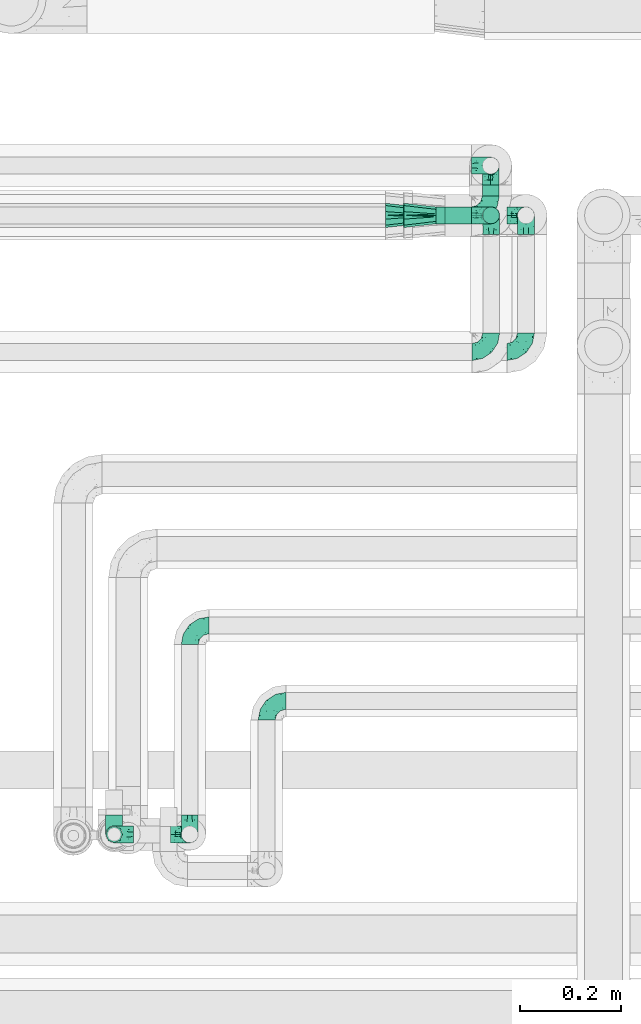
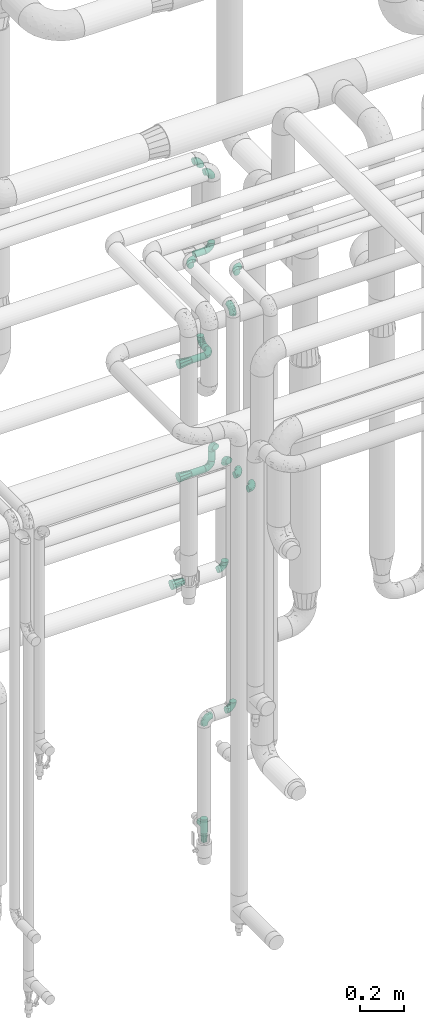
# One storey, part 776 of 827: 21 flow fittings, 5 flow segments.
"""IFC2X3 building model written with IfcOpenShell, lengths in millimetres."""

import ifcopenshell
import ifcopenshell.guid

model = None  # the IFC model being written
_history = None  # IfcOwnerHistory: only IFC2X3 demands one
_inside = {}  # id of a spatial element -> (the spatial element, [elements in it])
_under = {}  # id of a project, library or spatial element -> (it, [spatial elements below it])
_declared = {}  # id of a project -> (the project, [libraries it declares])
_typed = {}  # id of a type object -> (the type object, [elements of that type])
_made_of = {}  # id of a material, layer set ... -> (it, [elements and type objects made of it])


def new_model(schema):
    """Start an empty IFC model of exactly this schema.

    Asked for "IFC4X3", IfcOpenShell would pick the latest addendum, in which some entities
    have other attributes; the version numbers below select the first issue.
    IFC2X3 requires an IfcOwnerHistory on every rooted entity: one is made here for all.
    """
    global model, _history
    if schema == "IFC4X3":
        model = ifcopenshell.file(schema_version=(4, 3, 0, 0))
    else:
        model = ifcopenshell.file(schema=schema)
    _inside.clear()
    _under.clear()
    _declared.clear()
    _typed.clear()
    _made_of.clear()
    _history = None
    if model.schema == "IFC2X3":
        org = make("IfcOrganization", Name="unknown")
        user = make(
            "IfcPersonAndOrganization",
            ThePerson=make("IfcPerson", FamilyName="unknown"),
            TheOrganization=org,
        )
        app = make(
            "IfcApplication",
            ApplicationDeveloper=org,
            Version="unknown",
            ApplicationFullName="unknown",
            ApplicationIdentifier="unknown",
        )
        _history = make(
            "IfcOwnerHistory",
            OwningUser=user,
            OwningApplication=app,
            ChangeAction="ADDED",
            CreationDate=0,
        )
    return model


def make(cls, **values):
    """One entity of the class cls with the attributes given. An attribute that is None is left unset."""
    return model.create_entity(
        cls, **{name: value for name, value in values.items() if value is not None}
    )


def entity(cls, *values):
    """Any entity or typed value of the class cls, its attributes in the order of the schema. None: left unset."""
    e = model.create_entity(cls)
    for i, value in enumerate(values):
        if value is not None:
            e[i] = value
    return e


def rooted(cls, **values):
    """An entity with a GlobalId (a new one), such as an element, a storey or a relation."""
    return make(cls, GlobalId=ifcopenshell.guid.new(), OwnerHistory=_history, **values)


def si_unit(unit_type, name, prefix=None):
    """IfcSIUnit, for example si_unit("LENGTHUNIT", "METRE", prefix="MILLI")."""
    return make("IfcSIUnit", UnitType=unit_type, Prefix=prefix, Name=name)


def converted_unit(unit_type, name, factor, base, dimensions=None, offset=None):
    """IfcConversionBasedUnit, such as the inch: factor (a typed value) times the base unit."""
    return make(
        "IfcConversionBasedUnit"
        if offset is None
        else "IfcConversionBasedUnitWithOffset",
        ConversionOffset=offset,
        Dimensions=None
        if dimensions is None
        else entity("IfcDimensionalExponents", *dimensions),
        UnitType=unit_type,
        Name=name,
        ConversionFactor=make(
            "IfcMeasureWithUnit", ValueComponent=factor, UnitComponent=base
        ),
    )


def derived_unit(unit_type, elements):
    """IfcDerivedUnit: a product of units, each with its exponent."""
    return make(
        "IfcDerivedUnit",
        Elements=[
            make("IfcDerivedUnitElement", Unit=unit, Exponent=power)
            for unit, power in elements
        ],
        UnitType=unit_type,
    )


def assignment(units):
    """IfcUnitAssignment: the units of a project."""
    return None if units is None else make("IfcUnitAssignment", Units=units)


def point(xyz):
    """IfcCartesianPoint."""
    return None if xyz is None else make("IfcCartesianPoint", Coordinates=xyz)


def direction(xyz):
    """IfcDirection."""
    return None if xyz is None else make("IfcDirection", DirectionRatios=xyz)


def frame(location, z_axis=None, x_axis=None):
    """IfcAxis2Placement3D, a coordinate frame: its origin and axes. An axis left out is left unset."""
    return make(
        "IfcAxis2Placement3D",
        Location=point(location),
        Axis=direction(z_axis),
        RefDirection=direction(x_axis),
    )


def frame_2d(location, x_axis=None):
    """IfcAxis2Placement2D, a coordinate frame in the plane: its origin and x axis."""
    return make(
        "IfcAxis2Placement2D", Location=point(location), RefDirection=direction(x_axis)
    )


def origin():
    """The frame at (0, 0, 0) with its axes left unset."""
    return frame((0.0, 0.0, 0.0))


def origin_2d_with_axis():
    """The frame at (0, 0) in the plane with the x axis (1, 0) written out."""
    return frame_2d((0.0, 0.0), x_axis=(1.0, 0.0))


def place(relative_to, where):
    """IfcLocalPlacement: puts the frame where relative to a parent placement (None: the world)."""
    return make(
        "IfcLocalPlacement", PlacementRelTo=relative_to, RelativePlacement=where
    )


def context(
    kind, dimensions, precision=None, world=None, true_north=None, identifier=None
):
    """IfcGeometricRepresentationContext, for example the 3D "Model" context."""
    return make(
        "IfcGeometricRepresentationContext",
        ContextIdentifier=identifier,
        ContextType=kind,
        CoordinateSpaceDimension=dimensions,
        Precision=precision,
        WorldCoordinateSystem=world,
        TrueNorth=true_north,
    )


def subcontext(parent, identifier, kind, view, scale=None):
    """IfcGeometricRepresentationSubContext, for example "Body" below "Model"."""
    return make(
        "IfcGeometricRepresentationSubContext",
        ContextIdentifier=identifier,
        ContextType=kind,
        ParentContext=parent,
        TargetScale=scale,
        TargetView=view,
    )


def project(units=None, contexts=None):
    """IfcProject with its units and contexts."""
    return rooted(
        "IfcProject",
        Name="project",
        RepresentationContexts=contexts,
        UnitsInContext=assignment(units),
    )


def spatial(cls, under=None, at=None, **own):
    """A site, building, storey or space (cls), placed at a placement, below another one or the project."""
    s = rooted(cls, ObjectPlacement=at, **own)
    if under is not None:
        _under.setdefault(under.id(), (under, []))[1].append(s)
    return s


def profile(cls, at=None, kind="AREA", **sizes):
    """A parametric profile (cls). Its sizes go by their IFC names, for example OverallWidth=200.0."""
    return make(cls, ProfileType=kind, Position=at, **sizes)


def circle(**sizes):
    """IfcCircleProfileDef."""
    return profile("IfcCircleProfileDef", **sizes)


def extrude(swept, where, along, depth):
    """IfcExtrudedAreaSolid: the profile swept, set in the frame where, extruded along a direction by depth."""
    return make(
        "IfcExtrudedAreaSolid",
        SweptArea=swept,
        Position=where,
        ExtrudedDirection=direction(along),
        Depth=depth,
    )


def faces_of(points, faces, orient=None, outer=None):
    """IfcFace entities. A face is a list of loops; a loop is a list of indices into points, from 0.

    orient and outer hold one flag for each loop. By default every Orientation is true, the
    first loop of a face is its IfcFaceOuterBound and the others are IfcFaceBound.
    """
    made = []
    for i, loops in enumerate(faces):
        bounds = []
        for j, loop in enumerate(loops):
            is_outer = j == 0 if outer is None else outer[i][j]
            bounds.append(
                make(
                    "IfcFaceOuterBound" if is_outer else "IfcFaceBound",
                    Bound=make("IfcPolyLoop", Polygon=[points[k] for k in loop]),
                    Orientation=True if orient is None else orient[i][j],
                )
            )
        made.append(make("IfcFace", Bounds=bounds))
    return made


def faceted_brep(points, faces, orient=None, outer=None, voids=None):
    """IfcFacetedBrep: a solid bounded by flat faces; with voids (closed shells), ...WithVoids."""
    shared = [point(p) for p in points]
    hull = make("IfcClosedShell", CfsFaces=faces_of(shared, faces, orient, outer))
    if voids is None:
        return make("IfcFacetedBrep", Outer=hull)
    return make(
        "IfcFacetedBrepWithVoids",
        Outer=hull,
        Voids=[
            make(cls, CfsFaces=faces_of(shared, fs, o, b)) for cls, fs, o, b in voids
        ],
    )


def shape(context_of_items, identifier, shape_type, items):
    """IfcShapeRepresentation: the items that make up one representation, for example the "Body"."""
    return make(
        "IfcShapeRepresentation",
        ContextOfItems=context_of_items,
        RepresentationIdentifier=identifier,
        RepresentationType=shape_type,
        Items=items,
    )


def source(mapping_origin, context_of_items, identifier, shape_type, items):
    """IfcRepresentationMap: a shape defined once, which mapped items show again and again."""
    return make(
        "IfcRepresentationMap",
        MappingOrigin=mapping_origin,
        MappedRepresentation=shape(context_of_items, identifier, shape_type, items),
    )


def transform(
    local_origin,
    x_axis=None,
    y_axis=None,
    z_axis=None,
    scale=None,
    scale2=None,
    scale3=None,
    uniform=True,
):
    """IfcCartesianTransformationOperator3D, or its non-uniform kind. x_axis, y_axis, z_axis: its Axis1, 2, 3."""
    if uniform:
        return make(
            "IfcCartesianTransformationOperator3D",
            Axis1=direction(x_axis),
            Axis2=direction(y_axis),
            LocalOrigin=point(local_origin),
            Scale=scale,
            Axis3=direction(z_axis),
        )
    return make(
        "IfcCartesianTransformationOperator3DnonUniform",
        Axis1=direction(x_axis),
        Axis2=direction(y_axis),
        LocalOrigin=point(local_origin),
        Scale=scale,
        Axis3=direction(z_axis),
        Scale2=scale2,
        Scale3=scale3,
    )


def mapped(mapping_source, mapping_target):
    """IfcMappedItem: shows the shape of a source again, moved by a transform."""
    return make(
        "IfcMappedItem", MappingSource=mapping_source, MappingTarget=mapping_target
    )


def material(Name=None, Category=None):
    """IfcMaterial."""
    return make("IfcMaterial", Name=Name, Category=Category)


def made_of(thing, what):
    """Note that an element or type object is made of a material, layer set ...; save() writes the relation."""
    if what is not None:
        _made_of.setdefault(what.id(), (what, []))[1].append(thing)
    return thing


def type_object(cls, material=None, **own):
    """A type object (cls), such as IfcWallType, which elements share."""
    return made_of(rooted(cls, **own), material)


def type_shapes(of_type, sources):
    """Give a type object the sources (RepresentationMaps) that its elements show as mapped items."""
    of_type.RepresentationMaps = sources


def element(
    cls,
    number,
    at=None,
    inside=None,
    cuts=None,
    type_object=None,
    material=None,
    context=None,
    identifier="Body",
    shape_type=None,
    held_by="IfcProductDefinitionShape",
    body=None,
    shapes=None,
    **own,
):
    """One element of the class cls, such as IfcWall. Its Tag is "e" and its number.

    at: its placement. inside: the storey or other place that contains it. cuts: it is an
    opening in that element (IfcRelVoidsElement). A single representation is given by context,
    identifier, shape_type and body (its items); several are given by shapes. held_by: the class
    of the entity that holds the representations. save() writes the other relations.
    """
    e = rooted(cls, Tag="e%d" % number, ObjectPlacement=at, **own)
    if body is not None:
        shapes = [shape(context, identifier, shape_type, body)]
    if shapes is not None:
        e.Representation = make(held_by, Representations=shapes)
    if inside is not None:
        _inside.setdefault(inside.id(), (inside, []))[1].append(e)
    if cuts is not None:
        rooted(
            "IfcRelVoidsElement", RelatingBuildingElement=cuts, RelatedOpeningElement=e
        )
    if type_object is not None:
        _typed.setdefault(type_object.id(), (type_object, []))[1].append(e)
    return made_of(e, material)


def aggregate(whole, parts):
    """IfcRelAggregates: a whole, such as a stair, and the parts it consists of."""
    return rooted("IfcRelAggregates", RelatingObject=whole, RelatedObjects=parts)


def save(model, path):
    """Write the relations noted so far, then the file.

    IfcRelAggregates (storeys below a building ...), IfcRelContainedInSpatialStructure (elements
    in a storey), IfcRelDefinesByType, IfcRelAssociatesMaterial and IfcRelDeclares: one each for
    every whole, place, type object, material and project.
    """
    for whole, parts in _under.values():
        aggregate(whole, parts)
    for where, things in _inside.values():
        rooted(
            "IfcRelContainedInSpatialStructure",
            RelatedElements=things,
            RelatingStructure=where,
        )
    for kind, things in _typed.values():
        rooted("IfcRelDefinesByType", RelatedObjects=things, RelatingType=kind)
    for what, things in _made_of.values():
        rooted("IfcRelAssociatesMaterial", RelatedObjects=things, RelatingMaterial=what)
    for by, libraries in _declared.values():
        rooted("IfcRelDeclares", RelatingContext=by, RelatedDefinitions=libraries)
    model.write(path)


model = new_model("IFC2X3")

# Units and contexts
model_context = context("Model", 3, precision=0.01, world=origin(), true_north=direction((6.12303176911189e-17, 1.0)))
body_context = subcontext(model_context, "Body", "Model", "MODEL_VIEW")
ifc_project = project(units=[si_unit("LENGTHUNIT", "METRE", prefix="MILLI"), si_unit("AREAUNIT", "SQUARE_METRE"), si_unit("VOLUMEUNIT", "CUBIC_METRE"), converted_unit("PLANEANGLEUNIT", "DEGREE", entity("IfcRatioMeasure", 0.0174532925199433), si_unit("PLANEANGLEUNIT", "RADIAN"), dimensions=[0, 0, 0, 0, 0, 0, 0]), si_unit("MASSUNIT", "GRAM", prefix="KILO"), derived_unit("MASSDENSITYUNIT", [(si_unit("MASSUNIT", "GRAM", prefix="KILO"), 1), (si_unit("LENGTHUNIT", "METRE"), -3)]), derived_unit("MOMENTOFINERTIAUNIT", [(si_unit("LENGTHUNIT", "METRE"), 4)]), si_unit("TIMEUNIT", "SECOND"), si_unit("FREQUENCYUNIT", "HERTZ"), si_unit("THERMODYNAMICTEMPERATUREUNIT", "DEGREE_CELSIUS"), derived_unit("THERMALTRANSMITTANCEUNIT", [(si_unit("MASSUNIT", "GRAM", prefix="KILO"), 1), (si_unit("THERMODYNAMICTEMPERATUREUNIT", "KELVIN"), -1), (si_unit("TIMEUNIT", "SECOND"), -3)]), derived_unit("VOLUMETRICFLOWRATEUNIT", [(si_unit("LENGTHUNIT", "METRE"), 3), (si_unit("TIMEUNIT", "SECOND"), -1)]), derived_unit("MASSFLOWRATEUNIT", [(si_unit("MASSUNIT", "GRAM", prefix="KILO"), 1), (si_unit("TIMEUNIT", "SECOND"), -1)]), derived_unit("ROTATIONALFREQUENCYUNIT", [(si_unit("TIMEUNIT", "SECOND"), -1)]), si_unit("ELECTRICCURRENTUNIT", "AMPERE"), si_unit("ELECTRICVOLTAGEUNIT", "VOLT"), si_unit("POWERUNIT", "WATT"), si_unit("FORCEUNIT", "NEWTON", prefix="KILO"), si_unit("ILLUMINANCEUNIT", "LUX"), si_unit("LUMINOUSFLUXUNIT", "LUMEN"), si_unit("LUMINOUSINTENSITYUNIT", "CANDELA"), derived_unit("USERDEFINED", [(si_unit("MASSUNIT", "GRAM", prefix="KILO"), -1), (si_unit("LENGTHUNIT", "METRE"), -2), (si_unit("TIMEUNIT", "SECOND"), 3), (si_unit("LUMINOUSFLUXUNIT", "LUMEN"), 1)]), derived_unit("LINEARVELOCITYUNIT", [(si_unit("LENGTHUNIT", "METRE"), 1), (si_unit("TIMEUNIT", "SECOND"), -1)]), si_unit("PRESSUREUNIT", "PASCAL"), derived_unit("USERDEFINED", [(si_unit("LENGTHUNIT", "METRE"), -2), (si_unit("MASSUNIT", "GRAM", prefix="KILO"), 1), (si_unit("TIMEUNIT", "SECOND"), -2)]), derived_unit("LINEARFORCEUNIT", [(si_unit("MASSUNIT", "GRAM", prefix="KILO"), 1), (si_unit("LENGTHUNIT", "METRE"), 1), (si_unit("TIMEUNIT", "SECOND"), -2), (si_unit("LENGTHUNIT", "METRE"), -1)]), derived_unit("PLANARFORCEUNIT", [(si_unit("MASSUNIT", "GRAM", prefix="KILO"), 1), (si_unit("LENGTHUNIT", "METRE"), 1), (si_unit("TIMEUNIT", "SECOND"), -2), (si_unit("LENGTHUNIT", "METRE"), -2)])], contexts=[model_context])

# Site, building, storey
site_placement = place(None, origin())
site = spatial("IfcSite", under=ifc_project, at=site_placement, CompositionType="ELEMENT")
building_placement = place(site_placement, origin())
building = spatial("IfcBuilding", under=site, at=building_placement, CompositionType="ELEMENT")
storey_placement = place(building_placement, frame((0.0, 0.0, 28200.0)))
storey = spatial("IfcBuildingStorey", under=building, at=storey_placement, Name="08", CompositionType="ELEMENT", Elevation=28200.0)

# Flow segments
pipe_segment_type = type_object("IfcPipeSegmentType", PredefinedType="NOTDEFINED")
flow_segment_1_placement = place(storey_placement, frame((56544.88, 17538.0, 1974.15)))
element("IfcFlowSegment", 1, at=flow_segment_1_placement, inside=storey, type_object=pipe_segment_type, context=body_context, shape_type="SweptSolid", body=[
    extrude(circle(Radius=16.75, at=origin_2d_with_axis()), frame((18.35, 0.0, 18.35), z_axis=(0.0, 1.0, 0.0), x_axis=(-1.0, 0.0, 0.0)), (0.0, 0.0, 1.0), 22.8207544577575),
])
flow_segment_2_placement = place(storey_placement, frame((56454.69, 17481.65, 1974.15)))
element("IfcFlowSegment", 2, at=flow_segment_2_placement, inside=storey, type_object=pipe_segment_type, context=body_context, shape_type="SweptSolid", body=[
    extrude(circle(Radius=16.75, at=origin_2d_with_axis()), frame((0.0, 18.35, 18.35), z_axis=(1.0, 0.0, 0.0), x_axis=(0.0, 1.0, 0.0)), (0.0, 0.0, 1.0), 70.5388803777957),
])
flow_segment_3_placement = place(storey_placement, frame((56472.19, 17481.65, 2549.15)))
element("IfcFlowSegment", 3, at=flow_segment_3_placement, inside=storey, type_object=pipe_segment_type, context=body_context, shape_type="SweptSolid", body=[
    extrude(circle(Radius=16.75, at=origin_2d_with_axis()), frame((0.0, 18.35, 18.35), z_axis=(1.0, 0.0, 0.0), x_axis=(0.0, 1.0, 0.0)), (0.0, 0.0, 1.0), 53.0388803778343),
])
flow_segment_4_placement = place(storey_placement, frame((56454.23, 17481.65, 1351.65)))
element("IfcFlowSegment", 4, at=flow_segment_4_placement, inside=storey, type_object=pipe_segment_type, context=body_context, shape_type="SweptSolid", body=[
    extrude(circle(Radius=16.75, at=origin_2d_with_axis()), frame((0.0, 18.35, 18.35), z_axis=(1.0, 0.0, 0.0), x_axis=(0.0, 1.0, 0.0)), (0.0, 0.0, 1.0), 72.0000000000269),
])
flow_segment_5_placement = place(storey_placement, frame((56545.88, 17481.65, 1408.0)))
element("IfcFlowSegment", 5, at=flow_segment_5_placement, inside=storey, type_object=pipe_segment_type, context=body_context, shape_type="SweptSolid", body=[
    extrude(circle(Radius=16.75, at=origin_2d_with_axis()), frame((18.35, 18.35, 0.0)), (0.0, 0.0, 1.0), 54.0000000000267),
])

# Flow fittings
ifc_material = material()
pipe_fitting_type_1 = type_object("IfcPipeFittingType", Name="ADSK_1", PredefinedType="NOTDEFINED", material=ifc_material)
shared_shape_1 = source(origin(), body_context, "Body", "Brep", [
    faceted_brep([(-38.0, 0.0, -16.85), (-38.0, -4.36, -16.28), (-38.0, -8.43, -14.59), (-38.0, -11.91, -11.91), (-38.0, -14.59, -8.43), (-38.0, -16.28, -4.36), (-38.0, -16.85, 0.0), (-38.0, -16.28, 4.36), (-38.0, -14.59, 8.42), (-38.0, -11.91, 11.91), (-38.0, -8.43, 14.59), (-38.0, -4.36, 16.28), (-38.0, 0.0, 16.85), (-38.0, 4.36, 16.28), (-38.0, 8.42, 14.59), (-38.0, 11.91, 11.91), (-38.0, 14.59, 8.42), (-38.0, 16.28, 4.36), (-38.0, 16.85, 0.0), (-38.0, 16.28, -4.36), (-38.0, 14.59, -8.43), (-38.0, 11.91, -11.91), (-38.0, 8.42, -14.59), (-38.0, 4.36, -16.28), (-4.36, 38.0, -16.28), (-8.42, 38.0, -14.59), (-11.91, 38.0, -11.91), (-14.59, 38.0, -8.43), (-16.28, 38.0, -4.36), (-16.85, 38.0, 0.0), (-16.28, 38.0, 4.36), (-14.59, 38.0, 8.42), (-11.91, 38.0, 11.91), (-8.42, 38.0, 14.59), (-4.36, 38.0, 16.28), (0.0, 38.0, 16.85), (4.36, 38.0, 16.28), (8.43, 38.0, 14.59), (11.91, 38.0, 11.91), (14.59, 38.0, 8.42), (16.28, 38.0, 4.36), (16.85, 38.0, 0.0), (16.28, 38.0, -4.36), (14.59, 38.0, -8.43), (11.91, 38.0, -11.91), (8.43, 38.0, -14.59), (4.36, 38.0, -16.28), (0.0, 38.0, -16.85), (-27.9, -12.9, 9.54), (-27.5, -14.76, 0.0), (-16.53, -9.86, 8.66), (-24.93, -9.38, 12.63), (-29.29, -2.05, 16.58), (-26.82, 2.86, 16.81), (-25.18, -14.43, 5.37), (-4.54, 4.54, 14.04), (-15.36, -3.29, 14.19), (-7.56, -2.74, 10.9), (-28.06, -6.15, 15.21), (9.38, 24.93, 12.63), (-4.71, -4.42, 5.51), (-14.62, -10.99, 4.34), (-8.11, -6.73, 0.0), (-19.46, 0.42, 16.39), (-29.52, 14.25, 10.97), (-26.45, 18.14, 7.62), (-32.84, 15.94, 6.96), (-23.39, 16.22, 12.05), (-11.89, 8.53, 16.79), (-5.59, 13.42, 16.64), (-6.64, 18.62, 16.81), (-32.37, 10.35, 13.72), (-6.4, 32.67, 15.76), (-2.55, 28.48, 16.8), (6.81, 15.56, 11.71), (3.29, 15.36, 14.19), (-29.89, 18.0, 3.79), (-29.34, 6.81, 15.88), (-10.26, 4.27, 15.87), (-2.97, 11.0, 15.66), (2.45, 6.84, 10.65), (-1.8, -0.14, 8.44), (5.0, 5.5, 5.57), (-17.68, 27.4, 7.52), (14.43, 25.18, 5.37), (12.9, 27.9, 9.54), (9.86, 16.53, 8.66), (6.15, 28.06, 15.21), (-17.01, -12.67, 0.0), (2.05, 29.29, 16.58), (14.76, 27.5, 0.0), (10.99, 14.62, 4.34), (12.67, 17.01, 0.0), (-15.84, -6.82, 11.83), (-7.71, 25.61, 16.01), (-22.69, 22.69, 4.1), (-19.68, 27.42, 0.0), (-27.42, 19.68, 0.0), (-18.11, 29.67, 3.72), (-10.87, 29.33, 13.9), (-20.83, 21.64, 8.95), (-18.54, 20.86, 11.76), (-14.08, 30.19, 10.92), (-13.69, 20.27, 14.88), (-20.85, 7.92, 16.51), (-19.04, 4.79, 16.85), (-19.82, 12.26, 15.55), (-19.27, 16.43, 13.96), (-10.72, 19.56, 16.07), (-0.42, 19.46, 16.39), (-25.32, 12.08, 14.15), (-9.04, -6.0, 8.28), (-13.94, 13.94, 16.38), (0.78, -0.78, 0.0), (6.73, 8.11, 0.0), (-9.04, -6.0, -8.28), (-15.9, -7.04, -11.65), (-7.56, -2.74, -10.9), (6.15, 28.06, -15.21), (3.29, 15.36, -14.19), (-0.42, 19.46, -16.39), (-30.19, 14.08, -10.92), (-29.33, 10.87, -13.9), (-25.61, 7.71, -16.01), (-32.67, 6.4, -15.76), (-29.67, 18.11, -3.72), (-18.14, 26.45, -7.62), (-22.69, 22.69, -4.1), (-18.0, 29.89, -3.79), (-25.18, -14.43, -5.37), (-14.62, -10.99, -4.34), (-20.27, 13.69, -14.88), (-15.36, -3.29, -14.19), (-14.25, 29.52, -10.97), (-15.94, 32.84, -6.96), (-24.93, -9.38, -12.63), (-27.9, -12.9, -9.54), (6.81, 15.56, -11.71), (9.38, 24.93, -12.63), (-7.92, 20.85, -16.51), (-4.79, 19.04, -16.85), (-8.53, 11.89, -16.79), (-29.29, -2.05, -16.58), (-13.42, 5.59, -16.64), (-4.27, 10.26, -15.87), (-11.0, 2.97, -15.66), (-16.53, -9.86, -8.66), (-28.48, 2.55, -16.8), (-18.62, 6.64, -16.81), (10.99, 14.62, -4.34), (14.43, 25.18, -5.37), (-12.26, 19.82, -15.55), (-16.43, 19.27, -13.96), (12.9, 27.9, -9.54), (-10.35, 32.37, -13.72), (-6.81, 29.34, -15.88), (2.05, 29.29, -16.58), (-2.86, 26.82, -16.81), (-27.4, 17.68, -7.52), (5.0, 5.5, -5.57), (-16.22, 23.39, -12.05), (-28.06, -6.15, -15.21), (9.86, 16.53, -8.66), (-20.86, 18.54, -11.76), (-21.64, 20.83, -8.95), (-19.56, 10.72, -16.07), (-19.46, 0.42, -16.39), (-12.08, 25.32, -14.15), (-4.54, 4.54, -14.04), (-13.94, 13.94, -16.38), (2.45, 6.84, -10.65), (-4.71, -4.42, -5.51), (-1.8, -0.14, -8.44)], [[[0, 1, 2, 3, 4, 5, 6, 7, 8, 9, 10, 11, 12, 13, 14, 15, 16, 17, 18, 19, 20, 21, 22, 23]], [[24, 25, 26, 27, 28, 29, 30, 31, 32, 33, 34, 35, 36, 37, 38, 39, 40, 41, 42, 43, 44, 45, 46, 47]], [[8, 48, 9]], [[7, 6, 49]], [[48, 50, 51]], [[12, 52, 53]], [[8, 54, 48]], [[7, 54, 8]], [[55, 56, 57]], [[51, 10, 9]], [[51, 58, 10]], [[59, 38, 37]], [[60, 61, 62]], [[58, 56, 63]], [[64, 65, 66]], [[67, 65, 64]], [[68, 69, 70]], [[14, 71, 15]], [[11, 52, 12]], [[34, 72, 73]], [[12, 53, 13]], [[15, 64, 16]], [[74, 59, 75]], [[18, 17, 76]], [[66, 17, 16]], [[77, 13, 53]], [[13, 77, 14]], [[69, 78, 79]], [[80, 81, 82]], [[31, 30, 83]], [[84, 85, 86]], [[59, 87, 75]], [[61, 54, 88]], [[35, 89, 36]], [[84, 40, 39]], [[35, 34, 73]], [[90, 40, 84]], [[39, 38, 85]], [[10, 58, 11]], [[85, 84, 39]], [[91, 84, 86]], [[84, 92, 90]], [[87, 37, 36]], [[93, 56, 51]], [[94, 70, 73]], [[95, 96, 97]], [[84, 91, 92]], [[96, 98, 29]], [[33, 32, 99]], [[76, 95, 97]], [[100, 101, 83]], [[102, 99, 32]], [[65, 95, 76]], [[103, 94, 99]], [[95, 98, 96]], [[72, 99, 94]], [[72, 34, 33]], [[101, 99, 102]], [[7, 49, 54]], [[87, 59, 37]], [[104, 105, 68]], [[106, 103, 107]], [[106, 77, 104]], [[32, 31, 102]], [[94, 103, 108]], [[94, 108, 70]], [[89, 73, 109]], [[71, 64, 15]], [[110, 107, 67]], [[50, 48, 54]], [[51, 9, 48]], [[56, 58, 51]], [[88, 54, 49]], [[52, 58, 63]], [[50, 111, 93]], [[56, 55, 78]], [[38, 59, 85]], [[86, 85, 59]], [[89, 87, 36]], [[41, 40, 90]], [[109, 79, 75]], [[109, 75, 87]], [[75, 55, 80]], [[104, 77, 53]], [[71, 77, 110]], [[31, 83, 102]], [[101, 102, 83]], [[99, 101, 103]], [[106, 107, 110]], [[68, 70, 112]], [[109, 73, 70]], [[68, 112, 104]], [[68, 63, 78]], [[57, 93, 111]], [[80, 55, 57]], [[61, 50, 54]], [[80, 82, 86]], [[81, 57, 111]], [[74, 86, 59]], [[60, 113, 82]], [[82, 114, 91]], [[100, 95, 65]], [[98, 95, 83]], [[73, 89, 35]], [[87, 89, 109]], [[58, 52, 11]], [[53, 52, 63]], [[104, 53, 105]], [[106, 104, 112]], [[18, 76, 97]], [[76, 17, 66]], [[103, 106, 112]], [[77, 106, 110]], [[103, 101, 107]], [[67, 107, 101]], [[67, 101, 100]], [[110, 67, 64]], [[83, 30, 98]], [[29, 98, 30]], [[53, 63, 105]], [[63, 68, 105]], [[56, 78, 63]], [[79, 78, 55]], [[75, 79, 55]], [[69, 79, 109]], [[70, 69, 109]], [[78, 69, 68]], [[62, 113, 60]], [[111, 61, 60]], [[61, 88, 62]], [[86, 82, 91]], [[77, 71, 14]], [[114, 82, 113]], [[114, 92, 91]], [[64, 71, 110]], [[99, 72, 33]], [[73, 72, 94]], [[64, 66, 16]], [[76, 66, 65]], [[95, 100, 83]], [[67, 100, 65]], [[75, 80, 74]], [[80, 86, 74]], [[103, 112, 108]], [[70, 108, 112]], [[50, 93, 51]], [[57, 56, 93]], [[61, 111, 50]], [[81, 111, 60]], [[82, 81, 60]], [[80, 57, 81]], [[115, 116, 117]], [[118, 119, 120]], [[121, 122, 21]], [[123, 124, 122]], [[97, 125, 18]], [[126, 127, 128]], [[127, 97, 96]], [[129, 130, 88]], [[123, 122, 131]], [[116, 132, 117]], [[133, 126, 134]], [[22, 124, 23]], [[3, 135, 136]], [[137, 119, 138]], [[129, 88, 49]], [[139, 140, 141]], [[4, 3, 136]], [[45, 118, 46]], [[142, 1, 0]], [[143, 144, 145]], [[4, 129, 5]], [[129, 136, 146]], [[147, 0, 23]], [[22, 21, 122]], [[127, 125, 97]], [[123, 148, 147]], [[96, 128, 127]], [[149, 150, 92]], [[29, 28, 128]], [[151, 131, 152]], [[26, 133, 27]], [[153, 44, 43]], [[135, 3, 2]], [[26, 25, 154]], [[155, 25, 24]], [[47, 156, 157]], [[47, 46, 156]], [[20, 19, 158]], [[159, 149, 114]], [[126, 133, 160]], [[141, 143, 148]], [[45, 138, 118]], [[161, 135, 2]], [[155, 24, 157]], [[23, 124, 147]], [[115, 146, 116]], [[44, 153, 138]], [[138, 45, 44]], [[153, 162, 138]], [[161, 2, 1]], [[41, 90, 42]], [[130, 129, 146]], [[49, 5, 129]], [[42, 150, 43]], [[163, 122, 121]], [[47, 157, 24]], [[135, 161, 132]], [[134, 28, 27]], [[42, 90, 150]], [[164, 163, 158]], [[151, 155, 139]], [[21, 20, 121]], [[123, 131, 165]], [[123, 165, 148]], [[142, 147, 166]], [[154, 133, 26]], [[167, 152, 160]], [[146, 136, 135]], [[6, 5, 49]], [[129, 4, 136]], [[142, 161, 1]], [[166, 145, 132]], [[166, 132, 161]], [[132, 168, 117]], [[43, 150, 153]], [[92, 150, 90]], [[162, 153, 150]], [[119, 118, 138]], [[156, 118, 120]], [[137, 138, 162]], [[119, 168, 144]], [[139, 155, 157]], [[154, 155, 167]], [[20, 158, 121]], [[163, 121, 158]], [[122, 163, 131]], [[151, 152, 167]], [[141, 148, 169]], [[166, 147, 148]], [[141, 169, 139]], [[141, 120, 144]], [[168, 170, 117]], [[159, 171, 172]], [[115, 172, 171]], [[171, 62, 130]], [[119, 170, 168]], [[170, 162, 159]], [[149, 162, 150]], [[113, 171, 159]], [[164, 127, 126]], [[125, 127, 158]], [[147, 142, 0]], [[161, 142, 166]], [[118, 156, 46]], [[157, 156, 120]], [[139, 157, 140]], [[151, 139, 169]], [[29, 128, 96]], [[128, 28, 134]], [[131, 151, 169]], [[155, 151, 167]], [[131, 163, 152]], [[160, 152, 163]], [[160, 163, 164]], [[167, 160, 133]], [[158, 19, 125]], [[18, 125, 19]], [[157, 120, 140]], [[120, 141, 140]], [[119, 144, 120]], [[145, 144, 168]], [[132, 145, 168]], [[143, 145, 166]], [[148, 143, 166]], [[144, 143, 141]], [[115, 130, 146]], [[114, 113, 159]], [[62, 171, 113]], [[62, 88, 130]], [[159, 162, 149]], [[149, 92, 114]], [[155, 154, 25]], [[133, 154, 167]], [[122, 124, 22]], [[147, 124, 123]], [[133, 134, 27]], [[128, 134, 126]], [[127, 164, 158]], [[160, 164, 126]], [[162, 170, 137]], [[170, 119, 137]], [[131, 169, 165]], [[148, 165, 169]], [[146, 135, 116]], [[132, 116, 135]], [[172, 115, 117]], [[130, 115, 171]], [[117, 170, 172]], [[159, 172, 170]]]),
])
type_shapes(pipe_fitting_type_1, [shared_shape_1])
for number, where, z_axis, x_axis, name in (
    (6, (56118.13, 16535.69, 3200.0), (0.0, 0.0, 1.0), (-1.0, 0.0, 0.0), "ADSK_1"),
    (7, (55965.36, 16270.44, 3200.0), (1.0, 0.0, 0.0), (0.0, -1.0, 0.0), "ADSK_1"),
    (8, (55965.36, 16270.44, 1000.0), (0.0, 1.0, 0.0), (0.0, 0.0, -1.0), "ADSK_1"),
    (9, (55815.36, 16270.44, 1000.0), (0.0, -1.0, 0.0), (-1.0, 0.0, 0.0), "ADSK_1"),
    (10, (55965.36, 16685.69, 3200.0), (0.0, 0.0, 1.0), (-1.0, 0.0, 0.0), "ADSK_1"),
    (11, (56563.23, 17598.82, 3000.09), (0.0, 1.0, 0.0), (1.0, 0.0, 0.0), "ADSK_1"),
    (12, (56563.23, 17598.82, 1992.5), (-1.0, 0.0, 0.0), (0.0, 0.0, -1.0), "ADSK_1"),
):
    element("IfcFlowFitting", number, at=place(storey_placement, frame(where, z_axis=z_axis, x_axis=x_axis)), inside=storey, type_object=pipe_fitting_type_1, material=ifc_material, Name=name, ObjectType="ADSK_1", context=body_context, shape_type="MappedRepresentation", body=[
        mapped(shared_shape_1, transform((0.0, 0.0, 0.0), scale=1.0)),
    ])
flow_fitting_1_placement = place(storey_placement, frame((56563.23, 17500.0, 1992.5)))
element("IfcFlowFitting", 13, at=flow_fitting_1_placement, inside=storey, type_object=pipe_fitting_type_1, material=ifc_material, Name="ADSK_1", ObjectType="ADSK_1", context=body_context, shape_type="MappedRepresentation", body=[
    mapped(shared_shape_1, transform((0.0, 0.0, 0.0), scale=1.0)),
])
for number, where, z_axis, x_axis, name in (
    (14, (56563.23, 17500.0, 3000.0), (0.0, 1.0, 0.0), (1.0, 0.0, 0.0), "ADSK_1"),
    (15, (56563.23, 17500.0, 2567.5), (0.0, 1.0, 0.0), (0.0, 0.0, -1.0), "ADSK_1"),
):
    element("IfcFlowFitting", number, at=place(storey_placement, frame(where, z_axis=z_axis, x_axis=x_axis)), inside=storey, type_object=pipe_fitting_type_1, material=ifc_material, Name=name, ObjectType="ADSK_1", context=body_context, shape_type="MappedRepresentation", body=[
        mapped(shared_shape_1, transform((0.0, 0.0, 0.0), scale=1.0)),
    ])
flow_fitting_2_placement = place(storey_placement, frame((56564.23, 17228.56, 1500.0)))
element("IfcFlowFitting", 16, at=flow_fitting_2_placement, inside=storey, type_object=pipe_fitting_type_1, material=ifc_material, Name="ADSK_1", ObjectType="ADSK_1", context=body_context, shape_type="MappedRepresentation", body=[
    mapped(shared_shape_1, transform((0.0, 0.0, 0.0), scale=1.0)),
])
flow_fitting_3_placement = place(storey_placement, frame((56564.23, 17500.0, 1500.0), z_axis=(-1.0, 0.0, 0.0), x_axis=(0.0, 1.0, 0.0)))
element("IfcFlowFitting", 17, at=flow_fitting_3_placement, inside=storey, type_object=pipe_fitting_type_1, material=ifc_material, Name="ADSK_1", ObjectType="ADSK_1", context=body_context, shape_type="MappedRepresentation", body=[
    mapped(shared_shape_1, transform((0.0, 0.0, 0.0), scale=1.0)),
])
flow_fitting_4_placement = place(storey_placement, frame((56633.23, 17228.56, 1400.0)))
element("IfcFlowFitting", 18, at=flow_fitting_4_placement, inside=storey, type_object=pipe_fitting_type_1, material=ifc_material, Name="ADSK_1", ObjectType="ADSK_1", context=body_context, shape_type="MappedRepresentation", body=[
    mapped(shared_shape_1, transform((0.0, 0.0, 0.0), scale=1.0)),
])
for number, where, z_axis, x_axis, name in (
    (19, (56633.23, 17500.0, 1400.0), (-1.0, 0.0, 0.0), (0.0, 1.0, 0.0), "ADSK_1"),
    (20, (56633.23, 17500.0, 792.5), (0.0, 1.0, 0.0), (0.0, 0.0, -1.0), "ADSK_1"),
    (21, (56564.23, 17500.0, 1370.0), (0.0, 1.0, 0.0), (0.0, 0.0, -1.0), "ADSK_1"),
):
    element("IfcFlowFitting", number, at=place(storey_placement, frame(where, z_axis=z_axis, x_axis=x_axis)), inside=storey, type_object=pipe_fitting_type_1, material=ifc_material, Name=name, ObjectType="ADSK_1", context=body_context, shape_type="MappedRepresentation", body=[
        mapped(shared_shape_1, transform((0.0, 0.0, 0.0), scale=1.0)),
    ])
pipe_fitting_type_2 = type_object("IfcPipeFittingType", Name="ADSK_1", PredefinedType="NOTDEFINED", material=ifc_material)
shared_shape_2 = source(origin(), body_context, "Body", "Brep", [
    faceted_brep([(-38.0, 0.0, -16.85), (-38.0, -4.36, -16.28), (-38.0, -8.43, -14.59), (-38.0, -11.91, -11.91), (-38.0, -14.59, -8.43), (-38.0, -16.28, -4.36), (-38.0, -16.85, 0.0), (-38.0, -16.28, 4.36), (-38.0, -14.59, 8.42), (-38.0, -11.91, 11.91), (-38.0, -8.43, 14.59), (-38.0, -4.36, 16.28), (-38.0, 0.0, 16.85), (-38.0, 4.36, 16.28), (-38.0, 8.42, 14.59), (-38.0, 11.91, 11.91), (-38.0, 14.59, 8.42), (-38.0, 16.28, 4.36), (-38.0, 16.85, 0.0), (-38.0, 16.28, -4.36), (-38.0, 14.59, -8.43), (-38.0, 11.91, -11.91), (-38.0, 8.42, -14.59), (-38.0, 4.36, -16.28), (38.0, 4.36, -16.28), (38.0, 8.42, -14.59), (38.0, 11.91, -11.91), (38.0, 14.59, -8.43), (38.0, 16.28, -4.36), (38.0, 16.85, 0.0), (38.0, 16.28, 4.36), (38.0, 14.59, 8.42), (38.0, 11.91, 11.91), (38.0, 8.42, 14.59), (38.0, 4.36, 16.28), (38.0, 0.0, 16.85), (38.0, -4.36, 16.28), (38.0, -8.43, 14.59), (38.0, -11.91, 11.91), (38.0, -14.59, 8.42), (38.0, -16.28, 4.36), (38.0, -16.85, 0.0), (38.0, -16.28, -4.36), (38.0, -14.59, -8.43), (38.0, -11.91, -11.91), (38.0, -8.43, -14.59), (38.0, -4.36, -16.28), (38.0, 0.0, -16.85), (16.24, -16.24, 4.5), (16.85, -16.85, 0.0), (-16.85, -16.85, 0.0), (14.58, -14.58, 8.44), (9.44, -9.44, 13.95), (12.23, -12.23, 11.59), (-16.24, -16.24, 4.5), (-14.58, -14.58, 8.44), (-12.23, -12.23, 11.59), (-9.44, -9.44, 13.95), (-6.41, -6.41, 15.58), (6.41, -6.41, 15.58), (3.24, -3.24, 16.54), (0.0, 0.0, 16.85), (-3.24, -3.24, 16.54), (3.24, -3.24, -16.54), (0.0, 0.0, -16.85), (-3.24, -3.24, -16.54), (-6.41, -6.41, -15.58), (6.41, -6.41, -15.58), (9.44, -9.44, -13.95), (12.23, -12.23, -11.59), (14.58, -14.58, -8.44), (16.24, -16.24, -4.5), (-9.44, -9.44, -13.95), (-12.23, -12.23, -11.59), (-16.24, -16.24, -4.5), (-14.58, -14.58, -8.44), (4.36, -38.0, -16.28), (8.43, -38.0, -14.59), (11.91, -38.0, -11.91), (14.59, -38.0, -8.43), (16.28, -38.0, -4.36), (16.85, -38.0, 0.0), (16.28, -38.0, 4.36), (14.59, -38.0, 8.42), (11.91, -38.0, 11.91), (8.43, -38.0, 14.59), (4.36, -38.0, 16.28), (0.0, -38.0, 16.85), (-4.36, -38.0, 16.28), (-8.42, -38.0, 14.59), (-11.91, -38.0, 11.91), (-14.59, -38.0, 8.42), (-16.28, -38.0, 4.36), (-16.85, -38.0, 0.0), (-16.28, -38.0, -4.36), (-14.59, -38.0, -8.43), (-11.91, -38.0, -11.91), (-8.42, -38.0, -14.59), (-4.36, -38.0, -16.28), (0.0, -38.0, -16.85)], [[[0, 1, 2, 3, 4, 5, 6, 7, 8, 9, 10, 11, 12, 13, 14, 15, 16, 17, 18, 19, 20, 21, 22, 23]], [[24, 25, 26, 27, 28, 29, 30, 31, 32, 33, 34, 35, 36, 37, 38, 39, 40, 41, 42, 43, 44, 45, 46, 47]], [[40, 39, 48]], [[41, 40, 49]], [[50, 7, 6]], [[49, 40, 48]], [[39, 51, 48]], [[38, 37, 52]], [[51, 39, 53]], [[52, 53, 38]], [[53, 39, 38]], [[50, 54, 7]], [[7, 54, 8]], [[54, 55, 8]], [[56, 57, 9]], [[9, 8, 56]], [[9, 57, 10]], [[56, 8, 55]], [[10, 57, 58]], [[52, 37, 59]], [[60, 35, 61]], [[62, 61, 12]], [[59, 36, 60]], [[36, 59, 37]], [[60, 36, 35]], [[61, 35, 34, 13, 12]], [[31, 30, 17, 16]], [[15, 14, 33, 32]], [[16, 15, 32, 31]], [[34, 33, 14, 13]], [[18, 17, 30, 29]], [[62, 11, 58]], [[11, 62, 12]], [[58, 11, 10]], [[26, 21, 20, 27]], [[28, 19, 18, 29]], [[28, 27, 20, 19]], [[22, 21, 26, 25]], [[47, 46, 63]], [[47, 64, 0, 23, 24]], [[64, 47, 63]], [[0, 64, 65]], [[25, 24, 23, 22]], [[65, 66, 1]], [[0, 65, 1]], [[66, 2, 1]], [[63, 46, 67]], [[45, 44, 68]], [[69, 68, 44]], [[43, 70, 69]], [[69, 44, 43]], [[45, 68, 67]], [[42, 41, 49]], [[5, 50, 6]], [[42, 71, 43]], [[71, 42, 49]], [[43, 71, 70]], [[72, 2, 66]], [[72, 3, 2]], [[3, 72, 73]], [[3, 73, 4]], [[74, 50, 5]], [[75, 74, 4]], [[74, 5, 4]], [[75, 4, 73]], [[45, 67, 46]], [[76, 77, 78, 79, 80, 81, 82, 83, 84, 85, 86, 87, 88, 89, 90, 91, 92, 93, 94, 95, 96, 97, 98, 99]], [[50, 93, 92]], [[54, 50, 92]], [[90, 89, 57]], [[56, 91, 90]], [[54, 92, 91]], [[58, 89, 88]], [[55, 54, 91]], [[56, 55, 91]], [[58, 57, 89]], [[87, 61, 62]], [[58, 88, 62]], [[56, 90, 57]], [[62, 88, 87]], [[60, 87, 86]], [[85, 59, 86]], [[83, 82, 48]], [[53, 84, 83]], [[52, 85, 84]], [[49, 82, 81]], [[59, 60, 86]], [[52, 59, 85]], [[49, 48, 82]], [[51, 53, 83]], [[48, 51, 83]], [[52, 84, 53]], [[87, 60, 61]], [[81, 80, 49]], [[71, 49, 80]], [[69, 79, 78]], [[78, 77, 68]], [[71, 80, 79]], [[67, 77, 76]], [[70, 71, 79]], [[69, 70, 79]], [[67, 68, 77]], [[99, 64, 63]], [[67, 76, 63]], [[69, 78, 68]], [[63, 76, 99]], [[65, 99, 98]], [[97, 66, 98]], [[95, 94, 74]], [[73, 96, 95]], [[72, 97, 96]], [[50, 94, 93]], [[66, 65, 98]], [[72, 66, 97]], [[50, 74, 94]], [[75, 73, 95]], [[74, 75, 95]], [[72, 96, 73]], [[99, 65, 64]]]),
])
type_shapes(pipe_fitting_type_2, [shared_shape_2])
flow_fitting_5_placement = place(storey_placement, frame((55815.36, 16270.44, 408.5), z_axis=(-1.0, 0.0, 0.0), x_axis=(0.0, 0.0, -1.0)))
element("IfcFlowFitting", 22, at=flow_fitting_5_placement, inside=storey, type_object=pipe_fitting_type_2, material=ifc_material, Name="ADSK_1", ObjectType="ADSK_1", context=body_context, shape_type="MappedRepresentation", body=[
    mapped(shared_shape_2, transform((0.0, 0.0, 0.0), scale=1.0)),
])
pipe_fitting_type_3 = type_object("IfcPipeFittingType", Name="ADSK_1", PredefinedType="NOTDEFINED", material=ifc_material)
shared_shape_3 = source(origin(), body_context, "Body", "Brep", [
    faceted_brep([(51.0, -16.85, 0.0), (51.0, -15.39, -3.52), (51.0, -13.93, -7.04), (51.0, -11.91, -11.91), (51.0, -8.94, -13.15), (51.0, -5.96, -14.38), (51.0, -2.98, -15.62), (51.0, 0.0, -16.85), (51.0, 2.98, -15.62), (51.0, 5.96, -14.38), (51.0, 8.94, -13.15), (51.0, 11.91, -11.91), (51.0, 13.15, -8.94), (51.0, 14.38, -5.96), (51.0, 15.39, -3.52), (51.0, 16.85, 0.0), (51.0, 15.39, 3.52), (51.0, 13.93, 7.04), (51.0, 11.91, 11.91), (51.0, 8.94, 13.15), (51.0, 5.96, 14.38), (51.0, 2.98, 15.62), (51.0, 0.0, 16.85), (51.0, -2.98, 15.62), (51.0, -5.96, 14.38), (51.0, -8.94, 13.15), (51.0, -11.91, 11.91), (51.0, -13.15, 8.94), (51.0, -14.38, 5.96), (51.0, -15.39, 3.52), (0.0, -9.51, -9.51), (0.0, -10.5, -7.13), (0.0, -11.48, -4.76), (0.0, -12.47, -2.38), (0.0, -13.45, 0.0), (0.0, -12.47, 2.38), (0.0, -11.48, 4.76), (0.0, -10.5, 7.13), (0.0, -9.51, 9.51), (0.0, -7.13, 10.5), (0.0, -4.76, 11.48), (0.0, -2.38, 12.47), (0.0, 0.0, 13.45), (0.0, 2.38, 12.47), (0.0, 4.76, 11.48), (0.0, 7.13, 10.5), (0.0, 9.51, 9.51), (0.0, 10.5, 7.13), (0.0, 11.48, 4.76), (0.0, 12.47, 2.38), (0.0, 13.45, 0.0), (0.0, 12.47, -2.38), (0.0, 11.48, -4.76), (0.0, 10.5, -7.13), (0.0, 9.51, -9.51), (0.0, 7.13, -10.5), (0.0, 4.76, -11.48), (0.0, 2.38, -12.47), (0.0, 0.0, -13.45), (0.0, -2.38, -12.47), (0.0, -4.76, -11.48), (0.0, -7.13, -10.5)], [[[0, 1, 2, 3, 4, 5, 6, 7, 8, 9, 10, 11, 12, 13, 14, 15, 16, 17, 18, 19, 20, 21, 22, 23, 24, 25, 26, 27, 28, 29]], [[30, 31, 32, 33, 34, 35, 36, 37, 38, 39, 40, 41, 42, 43, 44, 45, 46, 47, 48, 49, 50, 51, 52, 53, 54, 55, 56, 57, 58, 59, 60, 61]], [[3, 2, 1, 0, 34, 33, 32, 31, 30]], [[11, 54, 53, 52, 51, 50, 15, 14, 13, 12]], [[58, 7, 6, 5, 4, 3, 30, 61, 60, 59]], [[56, 55, 54, 11, 10, 9, 8, 7, 58, 57]], [[18, 17, 16, 15, 50, 49, 48, 47, 46]], [[26, 38, 37, 36, 35, 34, 0, 29, 28, 27]], [[42, 22, 21, 20, 19, 18, 46, 45, 44, 43]], [[40, 39, 38, 26, 25, 24, 23, 22, 42, 41]]]),
])
type_shapes(pipe_fitting_type_3, [shared_shape_3])
flow_fitting_6_placement = place(storey_placement, frame((55815.36, 16270.44, 319.5), z_axis=(-1.0, 0.0, 0.0), x_axis=(0.0, 0.0, 1.0)))
element("IfcFlowFitting", 23, at=flow_fitting_6_placement, inside=storey, type_object=pipe_fitting_type_3, material=ifc_material, Name="ADSK_1", ObjectType="ADSK_1", context=body_context, shape_type="MappedRepresentation", body=[
    mapped(shared_shape_3, transform((0.0, 0.0, 0.0), scale=1.0)),
])
pipe_fitting_type_4 = type_object("IfcPipeFittingType", Name="ADSK_1", PredefinedType="NOTDEFINED", material=ifc_material)
shared_shape_4 = source(origin(), body_context, "Body", "Brep", [
    faceted_brep([(64.0, 16.85, 0.0), (64.0, 15.62, 2.98), (64.0, 14.38, 5.96), (64.0, 13.15, 8.94), (64.0, 11.91, 11.91), (64.0, 8.94, 13.15), (64.0, 5.96, 14.38), (64.0, 2.98, 15.62), (64.0, 0.0, 16.85), (64.0, -2.98, 15.62), (64.0, -5.96, 14.38), (64.0, -8.94, 13.15), (64.0, -11.91, 11.91), (64.0, -13.15, 8.94), (64.0, -14.38, 5.96), (64.0, -15.62, 2.98), (64.0, -16.85, 0.0), (64.0, -15.62, -2.98), (64.0, -14.38, -5.96), (64.0, -13.15, -8.94), (64.0, -11.91, -11.91), (64.0, -8.94, -13.15), (64.0, -5.96, -14.38), (64.0, -2.98, -15.62), (64.0, 0.0, -16.85), (64.0, 2.98, -15.62), (64.0, 5.96, -14.38), (64.0, 8.94, -13.15), (64.0, 11.91, -11.91), (64.0, 13.15, -8.94), (64.0, 14.38, -5.96), (64.0, 15.62, -2.98), (0.0, -24.15, 0.0), (0.0, -21.84, 7.1), (0.0, -19.54, 14.2), (0.0, -13.5, 18.58), (0.0, -7.46, 22.97), (0.0, 0.0, 22.97), (0.0, 7.46, 22.97), (0.0, 13.5, 18.58), (0.0, 19.54, 14.2), (0.0, 20.69, 10.65), (0.0, 21.84, 7.1), (0.0, 24.15, 0.0), (0.0, 21.84, -7.1), (0.0, 19.54, -14.2), (0.0, 13.5, -18.58), (0.0, 7.46, -22.97), (0.0, 0.0, -22.97), (0.0, -7.46, -22.97), (0.0, -13.5, -18.58), (0.0, -19.54, -14.2), (0.0, -20.69, -10.65), (0.0, -21.84, -7.1)], [[[0, 1, 2, 3, 4, 5, 6, 7, 8, 9, 10, 11, 12, 13, 14, 15, 16, 17, 18, 19, 20, 21, 22, 23, 24, 25, 26, 27, 28, 29, 30, 31]], [[32, 33, 34, 35, 36, 37, 38, 39, 40, 41, 42, 43, 44, 45, 46, 47, 48, 49, 50, 51, 52, 53]], [[51, 20, 19]], [[46, 45, 28]], [[18, 53, 52]], [[46, 28, 27, 26]], [[43, 31, 44]], [[26, 47, 46]], [[48, 25, 24]], [[29, 28, 45, 30]], [[20, 51, 50]], [[23, 48, 24]], [[32, 17, 16]], [[30, 45, 44]], [[50, 22, 21, 20]], [[17, 32, 53]], [[48, 23, 49]], [[47, 25, 48]], [[47, 26, 25]], [[23, 22, 49]], [[31, 43, 0]], [[18, 17, 53]], [[51, 19, 52]], [[19, 18, 52]], [[22, 50, 49]], [[31, 30, 44]], [[40, 4, 3]], [[35, 34, 12]], [[2, 42, 41]], [[35, 12, 11, 10]], [[32, 15, 33]], [[10, 36, 35]], [[37, 9, 8]], [[13, 12, 34, 14]], [[4, 40, 39]], [[7, 37, 8]], [[43, 1, 0]], [[14, 34, 33]], [[39, 6, 5, 4]], [[1, 43, 42]], [[37, 7, 38]], [[36, 9, 37]], [[36, 10, 9]], [[7, 6, 38]], [[15, 32, 16]], [[2, 1, 42]], [[40, 3, 41]], [[3, 2, 41]], [[6, 39, 38]], [[15, 14, 33]]]),
])
type_shapes(pipe_fitting_type_4, [shared_shape_4])
for number, where, name in (
    (24, (56354.23, 17500.0, 792.5), "ADSK_1"),
    (25, (56390.23, 17500.0, 1370.0), "ADSK_1"),
    (26, (56390.69, 17500.0, 1992.5), "ADSK_1"),
):
    element("IfcFlowFitting", number, at=place(storey_placement, frame(where)), inside=storey, type_object=pipe_fitting_type_4, material=ifc_material, Name=name, ObjectType="ADSK_1", context=body_context, shape_type="MappedRepresentation", body=[
        mapped(shared_shape_4, transform((0.0, 0.0, 0.0), scale=1.0)),
    ])

save(model, "model.ifc")
